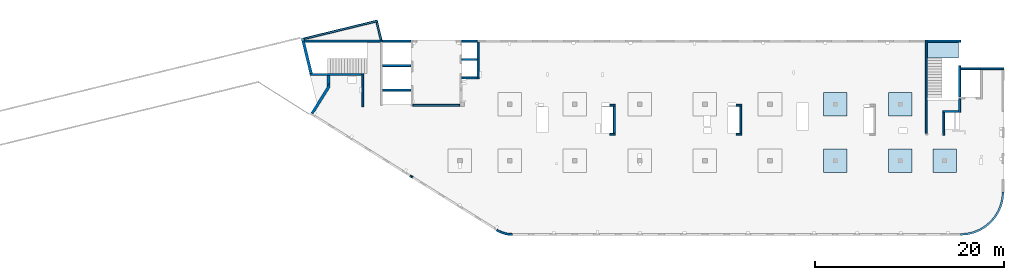
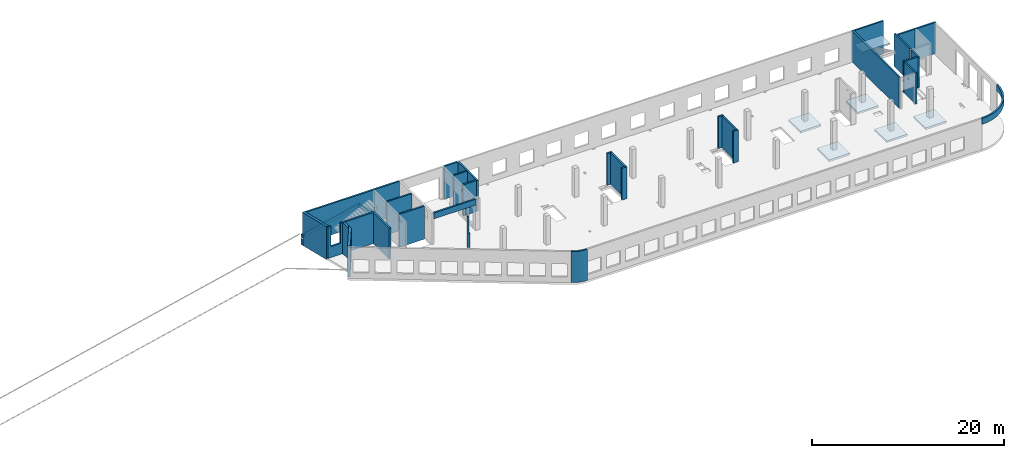
# One storey, part 2 of 8: 34 walls, 6 slabs, 2 openings.
"""IFC4 building model written with IfcOpenShell, lengths in millimetres."""

from ifc_helpers import new_model, entity, si_unit, converted_unit, derived_unit, direction, frame, origin, place, context, subcontext, project, spatial, indexed_curve, outline, extrude, polygons, material, type_object, element, save


model = new_model("IFC4")

# Units and contexts
model_context = context("Model", 3, precision=0.01, world=origin(), true_north=direction((6.12303176911189e-17, 1.0)))
plan_context = context("Plan", 3, precision=0.01, world=origin(), true_north=direction((6.12303176911189e-17, 1.0)))
body_context = subcontext(model_context, "Body", "Model", "MODEL_VIEW")
ifc_project = project(units=[si_unit("LENGTHUNIT", "METRE", prefix="MILLI"), si_unit("AREAUNIT", "SQUARE_METRE"), si_unit("VOLUMEUNIT", "CUBIC_METRE"), converted_unit("PLANEANGLEUNIT", "DEGREE", entity("IfcRatioMeasure", 0.0174532925199433), si_unit("PLANEANGLEUNIT", "RADIAN"), dimensions=[0, 0, 0, 0, 0, 0, 0]), si_unit("MASSUNIT", "GRAM", prefix="KILO"), derived_unit("MASSDENSITYUNIT", [(si_unit("MASSUNIT", "GRAM", prefix="KILO"), 1), (si_unit("LENGTHUNIT", "METRE"), -3)]), derived_unit("MOMENTOFINERTIAUNIT", [(si_unit("LENGTHUNIT", "METRE"), 4)]), si_unit("TIMEUNIT", "SECOND"), si_unit("FREQUENCYUNIT", "HERTZ"), si_unit("THERMODYNAMICTEMPERATUREUNIT", "DEGREE_CELSIUS"), derived_unit("THERMALTRANSMITTANCEUNIT", [(si_unit("MASSUNIT", "GRAM", prefix="KILO"), 1), (si_unit("THERMODYNAMICTEMPERATUREUNIT", "KELVIN"), -1), (si_unit("TIMEUNIT", "SECOND"), -3)]), derived_unit("VOLUMETRICFLOWRATEUNIT", [(si_unit("LENGTHUNIT", "METRE"), 3), (si_unit("TIMEUNIT", "SECOND"), -1)]), derived_unit("MASSFLOWRATEUNIT", [(si_unit("MASSUNIT", "GRAM", prefix="KILO"), 1), (si_unit("TIMEUNIT", "SECOND"), -1)]), derived_unit("ROTATIONALFREQUENCYUNIT", [(si_unit("TIMEUNIT", "SECOND"), -1)]), si_unit("ELECTRICCURRENTUNIT", "AMPERE"), si_unit("ELECTRICVOLTAGEUNIT", "VOLT"), si_unit("POWERUNIT", "WATT"), si_unit("FORCEUNIT", "NEWTON", prefix="KILO"), si_unit("ILLUMINANCEUNIT", "LUX"), si_unit("LUMINOUSFLUXUNIT", "LUMEN"), si_unit("LUMINOUSINTENSITYUNIT", "CANDELA"), derived_unit("USERDEFINED", [(si_unit("MASSUNIT", "GRAM", prefix="KILO"), -1), (si_unit("LENGTHUNIT", "METRE"), -2), (si_unit("TIMEUNIT", "SECOND"), 3), (si_unit("LUMINOUSFLUXUNIT", "LUMEN"), 1)]), derived_unit("LINEARVELOCITYUNIT", [(si_unit("LENGTHUNIT", "METRE"), 1), (si_unit("TIMEUNIT", "SECOND"), -1)]), si_unit("PRESSUREUNIT", "PASCAL"), derived_unit("USERDEFINED", [(si_unit("LENGTHUNIT", "METRE"), -2), (si_unit("MASSUNIT", "GRAM", prefix="KILO"), 1), (si_unit("TIMEUNIT", "SECOND"), -2)]), derived_unit("LINEARFORCEUNIT", [(si_unit("MASSUNIT", "GRAM", prefix="KILO"), 1), (si_unit("LENGTHUNIT", "METRE"), 1), (si_unit("TIMEUNIT", "SECOND"), -2), (si_unit("LENGTHUNIT", "METRE"), -1)]), derived_unit("PLANARFORCEUNIT", [(si_unit("MASSUNIT", "GRAM", prefix="KILO"), 1), (si_unit("LENGTHUNIT", "METRE"), 1), (si_unit("TIMEUNIT", "SECOND"), -2), (si_unit("LENGTHUNIT", "METRE"), -2)])], contexts=[model_context, plan_context])

# Site, building, storey
site_placement = place(None, origin())
site = spatial("IfcSite", under=ifc_project, at=site_placement, CompositionType="ELEMENT")
building_placement = place(site_placement, origin())
building = spatial("IfcBuilding", under=site, at=building_placement, CompositionType="ELEMENT")
storey_placement = place(building_placement, frame((0.0, 0.0, 24000.0)))
storey = spatial("IfcBuildingStorey", under=building, at=storey_placement, CompositionType="ELEMENT", Elevation=24000.0)

# Slabs
ifc_material = material()
slab_type_1 = type_object("IfcSlabType", PredefinedType="FLOOR", material=ifc_material)
slab_1_placement = place(storey_placement, origin())
element("IfcSlab", 1, at=slab_1_placement, inside=storey, type_object=slab_type_1, material=ifc_material, PredefinedType="FLOOR", context=body_context, shape_type="SweptSolid", body=[
    extrude(outline(indexed_curve([(-1250.0, -1249.99999999999), (1250.0, -1249.99999999999), (1250.0, 1250.00000000001), (-1250.0, 1250.00000000001), (-1250.0, -1249.99999999999)], self_intersect=False)), frame((55670.0002685547, 7699.99922635571, -400.0), z_axis=(0.0, 0.0, -1.0), x_axis=(0.0, 1.0, 0.0)), (0.0, 0.0, 1.0), 249.999999999999),
])
slab_type_2 = type_object("IfcSlabType", PredefinedType="FLOOR", material=ifc_material)
slab_2_placement = place(storey_placement, origin())
element("IfcSlab", 2, at=slab_2_placement, inside=storey, type_object=slab_type_2, material=ifc_material, PredefinedType="FLOOR", context=body_context, shape_type="SweptSolid", body=[
    extrude(outline(indexed_curve([(-1250.0, -1250.0), (1250.0, -1250.0), (1250.0, 1250.0), (-1250.0, 1250.0), (-1250.0, -1250.0)], self_intersect=False)), frame((62570.0002685547, 7699.99922635568, -400.0), z_axis=(0.0, 0.0, -1.0), x_axis=(0.0, 1.0, 0.0)), (0.0, 0.0, 1.0), 249.999999999999),
])
slab_type_3 = type_object("IfcSlabType", PredefinedType="FLOOR", material=ifc_material)
slab_3_placement = place(storey_placement, origin())
element("IfcSlab", 3, at=slab_3_placement, inside=storey, type_object=slab_type_3, material=ifc_material, PredefinedType="FLOOR", context=body_context, shape_type="SweptSolid", body=[
    extrude(outline(indexed_curve([(-1250.0, -1249.99999999999), (1250.0, -1249.99999999999), (1250.0, 1250.00000000001), (-1250.0, 1250.00000000001), (-1250.0, -1249.99999999999)], self_intersect=False)), frame((67270.0002685547, 7699.99922635567, -400.0), z_axis=(0.0, 0.0, -1.0), x_axis=(0.0, 1.0, 0.0)), (0.0, 0.0, 1.0), 249.999999999999),
])
slab_type_4 = type_object("IfcSlabType", PredefinedType="FLOOR", material=ifc_material)
slab_4_placement = place(storey_placement, origin())
element("IfcSlab", 4, at=slab_4_placement, inside=storey, type_object=slab_type_4, material=ifc_material, PredefinedType="FLOOR", context=body_context, shape_type="SweptSolid", body=[
    extrude(outline(indexed_curve([(-1250.0, -1250.0), (1250.0, -1250.0), (1250.0, 1250.0), (-1250.0, 1250.0), (-1250.0, -1250.0)], self_intersect=False)), frame((62570.0002685547, 13699.9992263555, -400.0), z_axis=(0.0, 0.0, -1.0), x_axis=(0.0, 1.0, 0.0)), (0.0, 0.0, 1.0), 249.999999999999),
])
slab_type_5 = type_object("IfcSlabType", PredefinedType="FLOOR", material=ifc_material)
slab_5_placement = place(storey_placement, origin())
element("IfcSlab", 5, at=slab_5_placement, inside=storey, type_object=slab_type_5, material=ifc_material, PredefinedType="FLOOR", context=body_context, shape_type="SweptSolid", body=[
    extrude(outline(indexed_curve([(-1250.0, -1250.0), (1250.0, -1250.0), (1250.0, 1250.0), (-1250.0, 1250.0), (-1250.0, -1250.0)], self_intersect=False)), frame((55670.0002685547, 13699.9992263555, -400.0), z_axis=(0.0, 0.0, -1.0), x_axis=(0.0, 1.0, 0.0)), (0.0, 0.0, 1.0), 249.999999999999),
])
slab_type_6 = type_object("IfcSlabType", PredefinedType="FLOOR", material=ifc_material)
slab_6_placement = place(storey_placement, origin())
element("IfcSlab", 6, at=slab_6_placement, inside=storey, type_object=slab_type_6, material=ifc_material, PredefinedType="FLOOR", context=body_context, shape_type="SweptSolid", body=[
    extrude(outline(indexed_curve([(-834.999999999999, -1670.00000000001), (835.000000000001, -1670.00000000001), (835.000000000001, 1670.00000000002), (-834.999999999999, 1670.00000000002), (-834.999999999999, -1670.00000000001)], self_intersect=False)), frame((67100.0002685547, 19464.999226356, 2070.0), z_axis=(0.0, 0.0, -1.0), x_axis=(0.0, 1.0, 0.0)), (0.0, 0.0, 1.0), 199.999999999998),
])

# Walls
wall_type_1 = type_object("IfcWallType", PredefinedType="STANDARD")
wall_1_placement = place(storey_placement, frame((71069.9994506836, 17469.9992263555, -150.0)))
element("IfcWall", 7, at=wall_1_placement, inside=storey, type_object=wall_type_1, material=ifc_material, PredefinedType="NOTDEFINED", context=body_context, shape_type="SweptSolid", body=[
    extrude(outline(indexed_curve([(2500.00000000001, 100.0), (-3.09390608370965e-13, 99.9999999999989), (3.09390608370965e-13, -99.9999999999989), (2500.00000000001, -99.9999999999977), (2500.00000000001, 100.0)], self_intersect=False)), origin(), (0.0, 0.0, 1.0), 3950.0),
])
wall_2_placement = place(storey_placement, frame((68870.0002685547, 14269.9992263555, -150.0), z_axis=(0.0, 0.0, 1.0), x_axis=(0.0, -1.0, 0.0)))
element("IfcWall", 8, at=wall_2_placement, inside=storey, type_object=wall_type_1, material=ifc_material, PredefinedType="NOTDEFINED", context=body_context, shape_type="SweptSolid", body=[
    extrude(outline(indexed_curve([(1439.99999999999, 100.000000000003), (0.0, 100.000000000003), (0.0, -100.000000000003), (1439.99999999999, -100.000000000003), (1439.99999999999, 100.000000000003)], self_intersect=False)), origin(), (0.0, 0.0, 1.0), 3950.0),
])
wall_3_placement = place(storey_placement, frame((68770.0002685547, 12929.9992263555, -150.0), z_axis=(0.0, 0.0, 1.0), x_axis=(-1.0, 0.0, 0.0)))
element("IfcWall", 9, at=wall_3_placement, inside=storey, type_object=wall_type_1, material=ifc_material, PredefinedType="NOTDEFINED", context=body_context, shape_type="SweptSolid", body=[
    extrude(outline(indexed_curve([(1689.99999999997, 99.9999999999989), (-3.84449868389964e-13, 99.9999999999989), (3.84449868389964e-13, -99.9999999999989), (1689.99999999997, -99.9999999999989), (1689.99999999997, 99.9999999999989)], self_intersect=False)), origin(), (0.0, 0.0, 1.0), 3950.0),
])
wall_4_placement = place(storey_placement, frame((67180.0002685547, 12829.9992263555, -150.0), z_axis=(0.0, 0.0, 1.0), x_axis=(0.0, -1.0, 0.0)))
element("IfcWall", 10, at=wall_4_placement, inside=storey, type_object=wall_type_1, material=ifc_material, PredefinedType="NOTDEFINED", context=body_context, shape_type="SweptSolid", body=[
    extrude(outline(indexed_curve([(2404.99999999995, 100.000000000003), (0.0, 100.000000000003), (0.0, -100.000000000003), (2404.99999999995, -100.000000000003), (2404.99999999995, 100.000000000003)], self_intersect=False)), origin(), (0.0, 0.0, 1.0), 3950.0),
])
wall_5_placement = place(storey_placement, frame((65330.0002685547, 10624.9992263555, -150.0), z_axis=(0.0, 0.0, 1.0), x_axis=(0.0, 1.0, 0.0)))
element("IfcWall", 11, at=wall_5_placement, inside=storey, type_object=wall_type_1, material=ifc_material, PredefinedType="NOTDEFINED", context=body_context, shape_type="SweptSolid", body=[
    extrude(outline(indexed_curve([(9875.00063936713, 100.000000000003), (-1.71685740578866e-13, 100.000000000003), (1.71685740578866e-13, -100.000000000003), (9875.00063936713, -100.000000000004), (9875.00063936713, 100.000000000003)], self_intersect=False)), origin(), (0.0, 0.0, 1.0), 3950.0),
])
wall_6_placement = place(storey_placement, frame((68970.0002685545, -99.9999557734324, 3050.0)))
element("IfcWall", 12, at=wall_6_placement, inside=storey, type_object=wall_type_1, material=ifc_material, PredefinedType="NOTDEFINED", context=body_context, shape_type="SweptSolid", body=[
    extrude(outline(indexed_curve([(4399.99918212903, 4499.99918212888), (4345.82789081698, 3811.68766389508), (4184.64789385715, 3140.32465961517), (3920.42797770043, 2502.44135458057), (3559.67411357824, 1913.74455277455), (3111.26925889869, 1388.72992323025), (2586.25462935438, 940.325068550716), (1997.55782754836, 579.571204428538), (1359.67452251375, 315.351288271842), (688.311518233829, 154.171291312031), (3.46517481375486e-11, 100.0), (0.0, -100.0), (719.598411241839, -43.3663768070014), (1421.47792138871, 125.139985012801), (2088.35592749623, 401.369899590849), (2703.81167981284, 778.521669675706), (3252.69061513597, 1247.30856699292), (3721.47751245321, 1796.18750231603), (4098.6292825381, 2411.64325463263), (4374.85919711618, 3078.52126074015), (4543.365558936, 3780.40077088701), (4599.99918212903, 4499.99918212885), (4399.99918212903, 4499.99918212888)], self_intersect=False)), origin(), (0.0, 0.0, 1.0), 750.000000000003),
])
wall_7_placement = place(storey_placement, frame((17825.0002685547, 20299.9998657227, -150.0), z_axis=(0.0, 0.0, 1.0), x_axis=(0.0, -1.0, 0.0)))
element("IfcWall", 13, at=wall_7_placement, inside=storey, type_object=wall_type_1, material=ifc_material, PredefinedType="NOTDEFINED", context=body_context, shape_type="SweptSolid", body=[
    extrude(outline(indexed_curve([(3900.00063936684, 99.9999999999989), (-1.66594915657375e-13, 99.9999999999989), (1.66594915657375e-13, -99.9999999999989), (3900.00063936684, -99.9999999999989), (3900.00063936684, 99.9999999999989)], self_intersect=False)), origin(), (0.0, 0.0, 1.0), 3950.0),
])
wall_8_placement = place(storey_placement, frame((17725.0002685547, 16499.9992263558, -150.0), z_axis=(0.0, 0.0, 1.0), x_axis=(-1.0, 0.0, 0.0)))
element("IfcWall", 14, at=wall_8_placement, inside=storey, type_object=wall_type_1, material=ifc_material, PredefinedType="NOTDEFINED", context=body_context, shape_type="SweptSolid", body=[
    extrude(outline(indexed_curve([(1624.99999999999, 99.9999999999982), (-3.56011111002209e-13, 99.9999999999989), (3.56011111002209e-13, -99.9999999999989), (1624.99999999999, -99.9999999999996), (1624.99999999999, 99.9999999999982)], self_intersect=False)), origin(), (0.0, 0.0, 1.0), 3950.0),
])
wall_9_placement = place(storey_placement, frame((5600.00026855469, 13449.9992263559, -150.0), z_axis=(0.0, 0.0, 1.0), x_axis=(0.0, 1.0, 0.0)))
element("IfcWall", 15, at=wall_9_placement, inside=storey, type_object=wall_type_1, material=ifc_material, PredefinedType="NOTDEFINED", context=body_context, shape_type="SweptSolid", body=[
    extrude(outline(indexed_curve([(3510.00000000004, 100.000000000001), (-1.37676332088153e-13, 100.0), (1.37676332088153e-13, -100.0), (3510.00000000004, -99.9999999999995), (3510.00000000004, 100.000000000001)], self_intersect=False)), origin(), (0.0, 0.0, 1.0), 3950.0),
])

# Wall, opening
wall_10_placement = place(storey_placement, frame((-29.466241120128, 16859.9992263559, -150.0)))
wall_10 = element("IfcWall", 16, at=wall_10_placement, inside=storey, type_object=wall_type_1, material=ifc_material, PredefinedType="NOTDEFINED", context=body_context, shape_type="Tessellation", body=[
    polygons([(48.7521159583314, -100.000000000001, 0.0), (1834.46650967482, -100.000000000001, 0.0), (2134.46650967482, -100.000000000001, 0.0), (5529.46650967482, -100.000000000001, 0.0), (5529.46650967482, -100.000000000001, 3950.0), (2134.46650967482, -100.000000000001, 3950.0), (1834.46650967482, -100.000000000001, 3950.0), (1559.46650967482, -100.000000000003, 3950.0), (1559.46650967482, -100.000000000003, 1400.00000000001), (459.466509674821, -99.9999999999989, 1400.00000000001), (459.466509674821, -100.000000000001, 3950.0), (48.7521159583309, -100.000000000001, 3950.0), (5529.46650967482, 99.9999999999989, 0.0), (-7.70689933091983e-14, 99.9999999999989, 0.0), (-7.70689933091983e-14, 99.9999999999989, 3950.0), (308.784277163577, 99.9999999999989, 3950.0), (459.466509674821, 99.9999999999989, 3950.0), (459.466509674822, 100.000000000319, 1400.00000000001), (1559.46650967482, 100.000000000319, 1400.00000000001), (1559.46650967482, 99.9999999999989, 3950.0), (1834.46650967482, 99.9999999999989, 3950.0), (5529.46650967482, 99.9999999999989, 3950.0)], [[[1, 2, 3, 4, 5, 6, 7, 8, 9, 10, 11, 12]], [[13, 14, 15, 16, 17, 18, 19, 20, 21, 22]], [[4, 3, 2, 1, 14, 13]], [[5, 22, 21, 20, 8, 7, 6]], [[5, 4, 13, 22]], [[1, 12, 15, 14]], [[10, 18, 17, 11]], [[18, 10, 9, 19]], [[19, 9, 8, 20]], [[15, 12, 11, 17, 16]]], closed=True),
])
opening_1_placement = place(wall_10_placement, origin())
element("IfcOpeningElement", 17, at=opening_1_placement, cuts=wall_10, PredefinedType="OPENING", context=body_context, shape_type="SweptSolid", body=[
    extrude(outline(indexed_curve([(-3150.0, -550.0), (3149.99999999999, -550.0), (3149.99999999999, 550.0), (-3150.0, 550.0), (-3150.0, -550.0)], self_intersect=False)), frame((1009.46650967482, -100.0, 4550.0), z_axis=(0.0, 1.0, 0.0), x_axis=(0.0, 0.0, -1.0)), (0.0, 0.0, 1.0), 200.000000000962),
])

# Walls
wall_11_placement = place(storey_placement, frame((7700.0002685547, 20399.9998657227, -150.0), z_axis=(0.0, 0.0, 1.0), x_axis=(-1.0, 0.0, 0.0)))
element("IfcWall", 18, at=wall_11_placement, inside=storey, type_object=wall_type_1, material=ifc_material, PredefinedType="NOTDEFINED", context=body_context, shape_type="SweptSolid", body=[
    extrude(outline(indexed_curve([(8283.59484082612, -100.000000000002), (8234.84272486779, 100.0), (200.0, 99.9999999999996), (-3.3419311609182e-13, 99.9999999999989), (3.34193116091834e-13, -100.000000000003), (8283.59484082612, -100.000000000002)], self_intersect=False)), origin(), (0.0, 0.0, 1.0), 3950.0),
])
wall_12_placement = place(storey_placement, frame((68870.0002685547, 17779.9992263555, -400.0), z_axis=(0.0, 0.0, 1.0), x_axis=(0.0, -1.0, 0.0)))
element("IfcWall", 19, at=wall_12_placement, inside=storey, type_object=wall_type_1, material=ifc_material, PredefinedType="NOTDEFINED", context=body_context, shape_type="SweptSolid", body=[
    extrude(outline(indexed_curve([(3310.0, 100.000000000003), (0.0, 100.000000000003), (0.0, -100.000000000003), (3310.0, -100.000000000003), (3310.0, 100.000000000003)], self_intersect=False)), origin(), (0.0, 0.0, 1.0), 4200.0),
])
wall_13_placement = place(storey_placement, frame((68970.0002685547, 17469.9992263555, -400.0)))
element("IfcWall", 20, at=wall_13_placement, inside=storey, type_object=wall_type_1, material=ifc_material, PredefinedType="NOTDEFINED", context=body_context, shape_type="SweptSolid", body=[
    extrude(outline(indexed_curve([(2099.99918212888, 99.9999999999989), (-3.09390728867033e-13, 99.9999999999989), (3.09390728867033e-13, -99.9999999999989), (2099.99918212888, -99.9999999999989), (2099.99918212888, 99.9999999999989)], self_intersect=False)), origin(), (0.0, 0.0, 1.0), 4200.0),
])
wall_14_placement = place(storey_placement, frame((65430.0002685547, 20399.9998657227, -400.0)))
element("IfcWall", 21, at=wall_14_placement, inside=storey, type_object=wall_type_1, material=ifc_material, PredefinedType="NOTDEFINED", context=body_context, shape_type="SweptSolid", body=[
    extrude(outline(indexed_curve([(3539.99999999995, 99.9999999999989), (-3.67073603151997e-13, 99.9999999999989), (3.67073603151997e-13, -99.9999999999989), (3539.99999999995, -99.9999999999989), (3539.99999999995, 99.9999999999989)], self_intersect=False)), origin(), (0.0, 0.0, 1.0), 4200.0),
])
wall_15_placement = place(storey_placement, frame((16100.0002685547, 20399.9998657227, -400.0)))
element("IfcWall", 22, at=wall_15_placement, inside=storey, type_object=wall_type_1, material=ifc_material, PredefinedType="NOTDEFINED", context=body_context, shape_type="SweptSolid", body=[
    extrude(outline(indexed_curve([(1624.99999999999, 99.9999999999989), (-2.66551908750372e-13, 99.9999999999989), (2.66551908750372e-13, -99.9999999999989), (1624.99999999999, -99.9999999999989), (1624.99999999999, 99.9999999999989)], self_intersect=False)), origin(), (0.0, 0.0, 1.0), 4200.0),
])
wall_16_placement = place(storey_placement, frame((16100.0002685547, 18449.9998657227, -400.0)))
element("IfcWall", 23, at=wall_16_placement, inside=storey, type_object=wall_type_1, material=ifc_material, PredefinedType="NOTDEFINED", context=body_context, shape_type="SweptSolid", body=[
    extrude(outline(indexed_curve([(1624.99999999999, 99.9999999999989), (-2.66551908750371e-13, 99.9999999999989), (2.66551908750371e-13, -99.9999999999989), (1624.99999999999, -99.9999999999989), (1624.99999999999, 99.9999999999989)], self_intersect=False)), origin(), (0.0, 0.0, 1.0), 4200.0),
])
for number, where in (
    (24, (7700.0002685547, 20399.9998657227, -400.0)),
    (25, (7700.0002685547, 17799.9998657227, -400.0)),
    (26, (7700.00026855469, 15199.9998657227, -400.0)),
):
    element("IfcWall", number, at=place(storey_placement, frame(where)), inside=storey, type_object=wall_type_1, material=ifc_material, PredefinedType="NOTDEFINED", context=body_context, shape_type="SweptSolid", body=[
        extrude(outline(indexed_curve([(3000.0, 99.9999999999989), (-2.88764567812902e-13, 99.9999999999989), (2.88764567812902e-13, -99.9999999999989), (3000.0, -99.9999999999989), (3000.0, 99.9999999999989)], self_intersect=False)), origin(), (0.0, 0.0, 1.0), 4200.0),
    ])
wall_17_placement = place(storey_placement, frame((7154.27999642214, 22536.2793175299, 550.0), z_axis=(0.0, 0.0, 1.0), x_axis=(-0.971552058141472, -0.23682609299034, 0.0)))
element("IfcWall", 27, at=wall_17_placement, inside=storey, type_object=wall_type_1, material=ifc_material, PredefinedType="NOTDEFINED", context=body_context, shape_type="SweptSolid", body=[
    extrude(outline(indexed_curve([(7999.9920696628, 100.000000000002), (3.63775676248679e-13, 100.0), (-3.63775676248679e-13, -100.0), (7999.9920696628, -99.9999999999981), (7999.9920696628, 100.000000000002)], self_intersect=False)), origin(), (0.0, 0.0, 1.0), 399.999999999996),
])
wall_18_placement = place(storey_placement, frame((7080.80739990703, 22415.4415024167, 550.0), z_axis=(0.0, 0.0, 1.0), x_axis=(0.236826092990339, -0.971552058141473, 0.0)))
element("IfcWall", 28, at=wall_18_placement, inside=storey, type_object=wall_type_1, material=ifc_material, PredefinedType="NOTDEFINED", context=body_context, shape_type="SweptSolid", body=[
    extrude(outline(indexed_curve([(1947.15147947281, -100.0), (1995.90359543114, 100.0), (1.29436461548949e-12, 99.9999999999997), (-1.29436461548949e-12, -99.9999999999997), (1947.15147947281, -100.0)], self_intersect=False)), origin(), (0.0, 0.0, 1.0), 399.999999999996),
])
wall_19_placement = place(storey_placement, frame((10900.0002685547, 13599.9992263559, 3050.0)))
element("IfcWall", 29, at=wall_19_placement, inside=storey, type_object=wall_type_1, material=ifc_material, PredefinedType="NOTDEFINED", context=body_context, shape_type="SweptSolid", body=[
    extrude(outline(indexed_curve([(4999.99925537109, 99.9999999999989), (-3.03202841358267e-13, 99.9999999999989), (3.03202841358267e-13, -99.9999999999989), (4999.99925537109, -99.9999999999989), (4999.99925537109, 99.9999999999989)], self_intersect=False)), origin(), (0.0, 0.0, 1.0), 750.000000000003),
])
wall_20_placement = place(storey_placement, frame((19823.5077523202, 370.436535143588, -150.0)))
element("IfcWall", 30, at=wall_20_placement, inside=storey, type_object=wall_type_1, material=ifc_material, PredefinedType="NOTDEFINED", context=body_context, shape_type="SweptSolid", body=[
    extrude(outline(indexed_curve([(1636.18152272799, -370.436490916867), (1469.39400500718, -365.506962801141), (1303.13894981314, -351.307211488465), (1137.93120555103, -327.881209893275), (974.282377378058, -295.301502213076), (812.699242896213, -253.668979278045), (653.682182794613, -203.112566118521), (497.723631301422, -143.788822717928), (345.306551243918, -75.8814591874654), (196.902938438973, 0.399233136038819), (52.9723600454957, 84.8170329073716), (-52.9723600454827, -84.8170329073819), (100.558460175235, -174.865542298412), (258.860668447987, -256.234195090284), (421.444044253667, -328.671013855484), (587.805109417498, -391.951680719459), (757.42868724919, -445.880232014374), (929.789497910372, -490.289665127326), (1104.35378506879, -525.042455663733), (1280.58096880202, -550.030983324403), (1457.92531963205, -565.177865177442), (1635.83764850666, -570.436195292948), (1636.18152272799, -370.436490916867)], self_intersect=False)), origin(), (0.0, 0.0, 1.0), 3950.0),
])
wall_21_placement = place(storey_placement, frame((31770.0002685547, 13599.9992263557, 0.0)))
element("IfcWall", 31, at=wall_21_placement, inside=storey, type_object=wall_type_1, material=ifc_material, PredefinedType="NOTDEFINED", context=body_context, shape_type="SweptSolid", body=[
    extrude(outline(indexed_curve([(600.000000000002, 100.0), (-5.41433564649185e-13, 99.9999999999989), (5.41433564649185e-13, -99.9999999999989), (600.000000000003, -99.9999999999978), (600.000000000002, 100.0)], self_intersect=False)), origin(), (0.0, 0.0, 1.0), 4050.0),
])
wall_22_placement = place(storey_placement, frame((32270.0002685547, 13499.9992263557, 0.0), z_axis=(0.0, 0.0, 1.0), x_axis=(0.0, -1.0, 0.0)))
element("IfcWall", 32, at=wall_22_placement, inside=storey, type_object=wall_type_1, material=ifc_material, PredefinedType="NOTDEFINED", context=body_context, shape_type="SweptSolid", body=[
    extrude(outline(indexed_curve([(2874.99985044025, 99.9999999999989), (-1.50659782348519e-13, 99.9999999999989), (1.50659782348519e-13, -99.9999999999989), (2874.99985044025, -99.9999999999989), (2874.99985044025, 99.9999999999989)], self_intersect=False)), origin(), (0.0, 0.0, 1.0), 4050.0),
])
wall_23_placement = place(storey_placement, frame((32370.0002685547, 10524.9993759155, 0.0), z_axis=(0.0, 0.0, 1.0), x_axis=(-1.0, 0.0, 0.0)))
element("IfcWall", 33, at=wall_23_placement, inside=storey, type_object=wall_type_1, material=ifc_material, PredefinedType="NOTDEFINED", context=body_context, shape_type="SweptSolid", body=[
    extrude(outline(indexed_curve([(599.999999999993, 99.9999999999978), (-5.41433564649196e-13, 99.9999999999989), (5.41433564649196e-13, -99.9999999999989), (599.999999999994, -100.0), (599.999999999993, 99.9999999999978)], self_intersect=False)), origin(), (0.0, 0.0, 1.0), 4050.0),
])
wall_24_placement = place(storey_placement, frame((45170.0002685547, 13599.9992263556, 0.0)))
element("IfcWall", 34, at=wall_24_placement, inside=storey, type_object=wall_type_1, material=ifc_material, PredefinedType="NOTDEFINED", context=body_context, shape_type="SweptSolid", body=[
    extrude(outline(indexed_curve([(600.000000000002, 99.9999999999978), (-5.41433564649196e-13, 99.9999999999989), (5.41433564649196e-13, -99.9999999999989), (600.000000000003, -100.0), (600.000000000002, 99.9999999999978)], self_intersect=False)), origin(), (0.0, 0.0, 1.0), 4050.0),
])
wall_25_placement = place(storey_placement, frame((45670.0002685547, 13499.9992263556, 0.0), z_axis=(0.0, 0.0, 1.0), x_axis=(0.0, -1.0, 0.0)))
element("IfcWall", 35, at=wall_25_placement, inside=storey, type_object=wall_type_1, material=ifc_material, PredefinedType="NOTDEFINED", context=body_context, shape_type="SweptSolid", body=[
    extrude(outline(indexed_curve([(2874.99985044015, 100.000000000003), (-3.01319564697061e-13, 100.000000000003), (3.01319564697061e-13, -100.000000000003), (2874.99985044015, -100.000000000003), (2874.99985044015, 100.000000000003)], self_intersect=False)), origin(), (0.0, 0.0, 1.0), 4050.0),
])
wall_26_placement = place(storey_placement, frame((45770.0002685547, 10524.9993759154, 0.0), z_axis=(0.0, 0.0, 1.0), x_axis=(-1.0, 0.0, 0.0)))
element("IfcWall", 36, at=wall_26_placement, inside=storey, type_object=wall_type_1, material=ifc_material, PredefinedType="NOTDEFINED", context=body_context, shape_type="SweptSolid", body=[
    extrude(outline(indexed_curve([(600.000000000002, 99.9999999999978), (-5.41433564649196e-13, 99.9999999999989), (5.41433564649196e-13, -99.9999999999989), (600.000000000003, -100.0), (600.000000000002, 99.9999999999978)], self_intersect=False)), origin(), (0.0, 0.0, 1.0), 4050.0),
])
wall_type_2 = type_object("IfcWallType", PredefinedType="STANDARD")
wall_27_placement = place(storey_placement, frame((233.05018952286, 12729.5913450927, -150.0), z_axis=(0.0, 0.0, 1.0), x_axis=(0.529911826412024, 0.848052743777575, 0.0)))
element("IfcWall", 37, at=wall_27_placement, inside=storey, type_object=wall_type_2, material=ifc_material, PredefinedType="NOTDEFINED", context=body_context, shape_type="SweptSolid", body=[
    extrude(outline(indexed_curve([(3292.51411367558, -150.000000000001), (3772.623842224, 150.0), (3206.4919216906, 150.0), (1.58200119670937e-12, 150.0), (9.05209240897875e-13, -150.0), (3292.51411367558, -150.000000000001)], self_intersect=False)), origin(), (0.0, 0.0, 1.0), 3950.0),
])
wall_28_placement = place(storey_placement, frame((-746.646040713773, 20535.5237796712, -400.0), z_axis=(0.0, 0.0, 1.0), x_axis=(0.236826092990339, -0.971552058141473, 0.0)))
element("IfcWall", 38, at=wall_28_placement, inside=storey, type_object=wall_type_2, material=ifc_material, PredefinedType="NOTDEFINED", context=body_context, shape_type="Tessellation", body=[
    polygons([(139.492179356616, -150.0, 0.0), (3467.29257433501, -150.000000000001, 0.0), (3643.65512861822, -150.000000000001, 0.0), (3643.65512861822, -150.000000000001, 249.999999999999), (3643.65512861822, -150.000000000001, 4200.0), (205.856184775741, -150.000000000001, 4200.0), (-4.33146851719357e-12, -150.000000000001, 4200.0), (-4.33146851719357e-12, -150.000000000001, 1350.0), (139.492179356616, -150.0, 1350.0), (139.492179356616, -150.000000000001, 950.000000000001), (205.856184775733, -149.999999999994, 950.000000000001), (205.856184775733, -149.999999999994, 749.999999999998), (139.492179356616, -150.000000000001, 749.999999999998), (3716.78330255572, 149.999999999999, 0.0), (3467.29257433501, 149.999999999999, 0.0), (139.492179356611, 149.999999999999, 0.0), (139.492179356611, 149.999999999999, 749.999999999998), (278.984358713227, 149.999999999999, 749.999999999998), (278.984358713227, 149.999999999998, 950.000000000001), (139.492179356611, 149.999999999999, 950.000000000001), (139.492179356611, 149.999999999999, 1350.0), (73.1281739374943, 149.999999999999, 1350.0), (73.1281739374986, 149.999999999999, 4200.0), (278.984358713223, 149.999999999999, 4200.0), (3716.78330255572, 149.999999999999, 4200.0), (3716.78330255572, 149.999999999999, 2470.0), (3716.78330255572, 149.999999999999, 2270.0)], [[[1, 2, 3, 4, 5, 6, 7, 8, 9, 10, 11, 12, 13]], [[14, 15, 16, 17, 18, 19, 20, 21, 22, 23, 24, 25, 26, 27]], [[3, 2, 1, 16, 15, 14]], [[7, 6, 5, 25, 24, 23]], [[5, 4, 3, 14, 27, 26, 25]], [[9, 21, 20, 10]], [[22, 21, 9, 8]], [[8, 7, 23, 22]], [[12, 18, 17, 13]], [[19, 11, 10, 20]], [[18, 12, 11, 19]], [[16, 1, 13, 17]]], closed=True),
])
wall_29_placement = place(storey_placement, frame((1955.00026855469, 16759.9992263559, -150.0), z_axis=(0.0, 0.0, 1.0), x_axis=(0.0, -1.0, 0.0)))
element("IfcWall", 39, at=wall_29_placement, inside=storey, type_object=wall_type_2, material=ifc_material, PredefinedType="NOTDEFINED", context=body_context, shape_type="SweptSolid", body=[
    extrude(outline(indexed_curve([(1231.64683521102, -150.0), (751.537106662604, 150.0), (-2.44623692705516e-13, 150.0), (2.44623692705516e-13, -150.0), (1231.64683521102, -150.0)], self_intersect=False)), origin(), (0.0, 0.0, 1.0), 3950.0),
])

# Wall, opening
wall_30_placement = place(storey_placement, frame((-787.544181994441, 20703.3037435836, -400.0), z_axis=(0.0, 0.0, 1.0), x_axis=(0.236826092990258, -0.971552058141492, 0.0)))
wall_30 = element("IfcWall", 40, at=wall_30_placement, inside=storey, type_object=wall_type_2, material=ifc_material, PredefinedType="NOTDEFINED", context=body_context, shape_type="SweptSolid", body=[
    extrude(outline(indexed_curve([(312.184895620594, 150.0), (5.66813262992127e-13, 150.0), (-5.66813262992127e-13, -150.0), (312.184895620592, -150.0), (312.184895620594, 150.0)], self_intersect=False)), origin(), (0.0, 0.0, 1.0), 1350.00000000001),
])
opening_2_placement = place(storey_placement, frame((-787.544181994441, 20703.3037435836, -400.0), z_axis=(0.0, 0.0, 1.0), x_axis=(0.236826092990258, -0.971552058141492, 0.0)))
element("IfcOpeningElement", 41, at=opening_2_placement, cuts=wall_30, PredefinedType="OPENING", context=body_context, shape_type="SweptSolid", body=[
    extrude(outline(indexed_curve([(-156.092447810279, -149.999999999999), (156.092447810287, -149.999999999999), (156.092447810288, 150.000000000001), (-156.092447810305, 150.0), (-156.092447810279, -149.999999999999)], self_intersect=False)), frame((156.09244781031, 0.0, 750.0)), (0.0, 0.0, 1.0), 200.000000000002),
])

# Wall
wall_type_3 = type_object("IfcWallType", PredefinedType="NOTDEFINED", material=ifc_material)
wall_31_placement = place(storey_placement, frame((10577.4267542071, 5877.00804371445, 4050.0)))
element("IfcWall", 42, at=wall_31_placement, inside=storey, type_object=wall_type_3, material=ifc_material, PredefinedType="NOTDEFINED", context=body_context, shape_type="Tessellation", body=[
    polygons([(160.036576182802, 52.991182641201, 3950.0), (217.384704172807, 252.991182641207, 3950.0), (105.982365282413, 322.601731396727, 3950.0), (0.0, 152.991182641199, 3950.0), (0.0, 152.991182641199, 0.0), (105.982365282413, 322.601731396727, 0.0), (350.824215842971, 169.610548755526, 0.0), (244.841850560567, 1.29944055515807e-11, 0.0), (160.036576182802, 52.9911826411999, 1770.0), (217.384704172807, 252.991182641207, 1770.0), (350.824215842971, 169.610548755528, 1770.0), (244.841850560567, 1.40772726808791e-11, 1770.0)], [[[1, 2, 3, 4]], [[5, 6, 7, 8]], [[2, 1, 9, 10]], [[3, 2, 10, 11, 7, 6]], [[4, 3, 6, 5]], [[1, 4, 5, 8, 12, 9]], [[10, 9, 12, 11]], [[8, 7, 11, 12]]], closed=True),
])

save(model, "model.ifc")
